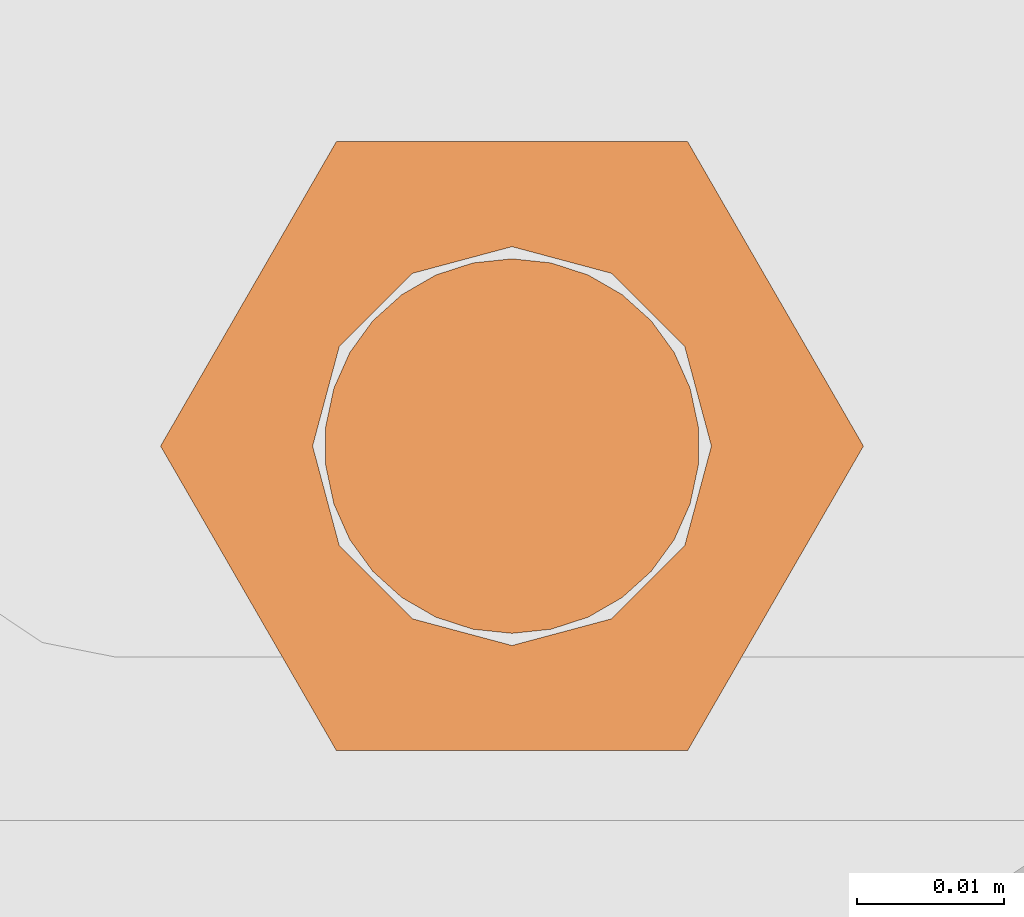
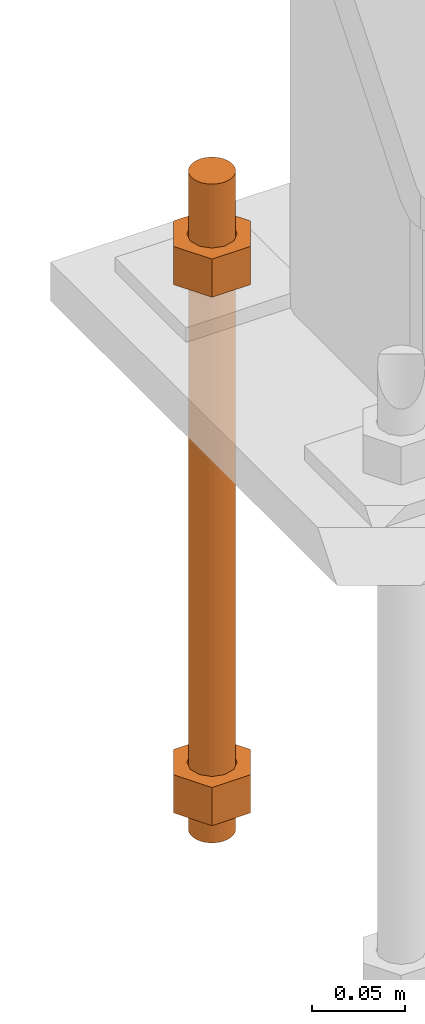
# One storey, part 28 of 89: 1 proxy.
"""IFC4 building model written with IfcOpenShell, lengths in feet."""

from ifc_helpers import new_model, entity, si_unit, converted_unit, derived_unit, direction, frame, origin, place, context, subcontext, project, spatial, faceted_brep, source, transform, mapped, material, constituent, constituent_set, type_object, type_shapes, element, save


model = new_model("IFC4")

# Units and contexts
model_context = context("Model", 3, precision=0.0001, world=origin(), true_north=direction((6.12303176911189e-17, 1.0)))
body_context = subcontext(model_context, "Body", "Model", "MODEL_VIEW")
ifc_project = project(units=[converted_unit("LENGTHUNIT", "FOOT", entity("IfcRatioMeasure", 0.3048), si_unit("LENGTHUNIT", "METRE"), dimensions=[1, 0, 0, 0, 0, 0, 0]), converted_unit("AREAUNIT", "SQUARE FOOT", entity("IfcRatioMeasure", 0.09290304), si_unit("AREAUNIT", "SQUARE_METRE"), dimensions=[2, 0, 0, 0, 0, 0, 0]), converted_unit("VOLUMEUNIT", "CUBIC FOOT", entity("IfcRatioMeasure", 0.028316846592), si_unit("VOLUMEUNIT", "CUBIC_METRE"), dimensions=[3, 0, 0, 0, 0, 0, 0]), si_unit("PLANEANGLEUNIT", "RADIAN"), si_unit("MASSUNIT", "GRAM", prefix="KILO"), derived_unit("MASSDENSITYUNIT", [(si_unit("MASSUNIT", "GRAM", prefix="KILO"), 1), (si_unit("LENGTHUNIT", "METRE"), -3)]), derived_unit("MOMENTOFINERTIAUNIT", [(si_unit("LENGTHUNIT", "METRE"), 4)]), si_unit("TIMEUNIT", "SECOND"), si_unit("FREQUENCYUNIT", "HERTZ"), si_unit("THERMODYNAMICTEMPERATUREUNIT", "DEGREE_CELSIUS"), derived_unit("THERMALTRANSMITTANCEUNIT", [(si_unit("MASSUNIT", "GRAM", prefix="KILO"), 1), (si_unit("THERMODYNAMICTEMPERATUREUNIT", "KELVIN"), -1), (si_unit("TIMEUNIT", "SECOND"), -3)]), derived_unit("VOLUMETRICFLOWRATEUNIT", [(si_unit("LENGTHUNIT", "METRE"), 3), (si_unit("TIMEUNIT", "SECOND"), -1)]), si_unit("ELECTRICCURRENTUNIT", "AMPERE"), si_unit("ELECTRICVOLTAGEUNIT", "VOLT"), si_unit("POWERUNIT", "WATT"), si_unit("FORCEUNIT", "NEWTON"), si_unit("ILLUMINANCEUNIT", "LUX"), si_unit("LUMINOUSFLUXUNIT", "LUMEN"), si_unit("LUMINOUSINTENSITYUNIT", "CANDELA"), derived_unit("USERDEFINED", [(si_unit("MASSUNIT", "GRAM", prefix="KILO"), -1), (si_unit("LENGTHUNIT", "METRE"), -2), (si_unit("TIMEUNIT", "SECOND"), 3), (si_unit("LUMINOUSFLUXUNIT", "LUMEN"), 1)]), derived_unit("LINEARVELOCITYUNIT", [(si_unit("LENGTHUNIT", "METRE"), 1), (si_unit("TIMEUNIT", "SECOND"), -1)]), si_unit("PRESSUREUNIT", "PASCAL"), derived_unit("USERDEFINED", [(si_unit("LENGTHUNIT", "METRE"), -2), (si_unit("MASSUNIT", "GRAM", prefix="KILO"), 1), (si_unit("TIMEUNIT", "SECOND"), -2)]), derived_unit("LINEARFORCEUNIT", [(si_unit("MASSUNIT", "GRAM", prefix="KILO"), 1), (si_unit("LENGTHUNIT", "METRE"), 1), (si_unit("TIMEUNIT", "SECOND"), -2), (si_unit("LENGTHUNIT", "METRE"), -1)]), derived_unit("PLANARFORCEUNIT", [(si_unit("MASSUNIT", "GRAM", prefix="KILO"), 1), (si_unit("LENGTHUNIT", "METRE"), 1), (si_unit("TIMEUNIT", "SECOND"), -2), (si_unit("LENGTHUNIT", "METRE"), -2)])], contexts=[model_context])

# Site, building, storey
site_placement = place(None, origin())
site = spatial("IfcSite", under=ifc_project, at=site_placement, CompositionType="ELEMENT")
building_placement = place(site_placement, frame((-472.238160486, -49.138065117, 0.0)))
building = spatial("IfcBuilding", under=site, at=building_placement, CompositionType="ELEMENT")
storey_placement = place(building_placement, origin())
storey = spatial("IfcBuildingStorey", under=building, at=storey_placement, Name="Level 1", CompositionType="ELEMENT", Elevation=0.0)

# Proxy
ifc_material_1 = material(Name="Color 7721", Category="Materials")
ifc_constituent_1 = constituent(ifc_material_1, Name="Color 7721", Category="Materials")
ifc_material_2 = material(Name="Color 7720", Category="Materials")
ifc_constituent_2 = constituent(ifc_material_2, Name="Color 7720", Category="Materials")
ifc_constituent_set = constituent_set(constituents=[ifc_constituent_1, ifc_constituent_2])
building_element_proxy_type = type_object("IfcBuildingElementProxyType", Name="rb2", PredefinedType="NOTDEFINED", material=ifc_material_1)
shared_shape = source(origin(), body_context, "Body", "Brep", [
    faceted_brep([(0.122545547339286, 0.0677083333333712, 0.0626666666666664), (0.156365697905557, 0.0677083333333712, 0.0626666666666664), (0.11727427342916, 0.135416666666742, 0.0626666666666664), (0.0390914244764247, 0.135416666666742, 0.0626666666666664), (0.0, 0.0677083333333712, 0.0626666666666664), (0.0338201505662994, 0.0677083333333712, 0.0626666666666664), (0.0397636251696838, 0.089889682526632, 0.0626666666666664), (0.0560014997595601, 0.106127557116452, 0.0626666666666664), (0.0781828489527925, 0.112071031719893, 0.0626666666666664), (0.100364198146025, 0.106127557116452, 0.0626666666666664), (0.116602072735901, 0.089889682526632, 0.0626666666666664), (0.11727427342916, 0.0, 0.0626666666666664), (0.0390914244764247, 0.0, 0.0626666666666664), (0.0397636251696838, 0.0455269841401105, 0.0626666666666664), (0.0560014997595601, 0.029289109550291, 0.0626666666666664), (0.0781828489527925, 0.0233456349468497, 0.0626666666666664), (0.100364198146025, 0.029289109550291, 0.0626666666666664), (0.116602072735901, 0.0455269841401105, 0.0626666666666664), (0.0, 0.0677083333333712, 0.144697916666667), (0.0390914244763962, 0.135416666666742, 0.144697916666667), (0.11727427342916, 0.135416666666742, 0.144697916666667), (0.156365697905528, 0.0677083333333712, 0.144697916666667), (0.117274273429189, 0.0, 0.144697916666667), (0.0390914244764247, 0.0, 0.144697916666667), (0.122545547339286, 0.0677083333333712, 0.144697916666666), (0.0338201505662994, 0.0677083333333712, 0.144697916666666), (0.0397636251696838, 0.0455269841401105, 0.144697916666666), (0.0560014997595601, 0.029289109550291, 0.144697916666666), (0.0781828489527925, 0.0233456349468497, 0.144697916666666), (0.100364198146025, 0.029289109550291, 0.144697916666666), (0.116602072735901, 0.0455269841401105, 0.144697916666666), (0.0397636251696838, 0.089889682526632, 0.144697916666666), (0.0560014997595601, 0.106127557116452, 0.144697916666666), (0.0781828489527925, 0.112071031719893, 0.144697916666666), (0.100364198146025, 0.106127557116452, 0.144697916666666), (0.116602072735901, 0.089889682526632, 0.144697916666666)], [[[0, 1, 2, 3, 4, 5, 6, 7, 8, 9, 10]], [[1, 11, 12, 4, 5, 13, 14, 15, 16, 17, 0]], [[4, 18, 19, 3]], [[3, 19, 20, 2]], [[2, 20, 21, 1]], [[1, 21, 22, 11]], [[11, 22, 23, 12]], [[12, 23, 18, 4]], [[24, 21, 22, 23, 18, 25, 26, 27, 28, 29, 30]], [[21, 20, 19, 18, 25, 31, 32, 33, 34, 35, 24]], [[25, 5, 6, 31]], [[31, 6, 7, 32]], [[32, 7, 8, 33]], [[33, 8, 9, 34]], [[34, 9, 10, 35]], [[35, 10, 0, 24]], [[24, 0, 17, 30]], [[30, 17, 16, 29]], [[29, 16, 15, 28]], [[28, 15, 14, 27]], [[27, 14, 13, 26]], [[26, 13, 5, 25]]]),
    faceted_brep([(0.0338201505662994, 0.0677083333333712, 1.28108333333333), (0.0, 0.0677083333333712, 1.28108333333333), (0.0390914244764247, 0.135416666666742, 1.28108333333333), (0.11727427342916, 0.135416666666742, 1.28108333333333), (0.156365697905557, 0.0677083333333712, 1.28108333333333), (0.122545547339286, 0.0677083333333712, 1.28108333333333), (0.116602072735901, 0.089889682526632, 1.28108333333333), (0.100364198146025, 0.106127557116452, 1.28108333333333), (0.0781828489527925, 0.112071031719893, 1.28108333333333), (0.0560014997595601, 0.106127557116452, 1.28108333333333), (0.0397636251696838, 0.089889682526632, 1.28108333333333), (0.0390914244764247, 0.0, 1.28108333333333), (0.11727427342916, 0.0, 1.28108333333333), (0.116602072735901, 0.0455269841401105, 1.28108333333333), (0.100364198146025, 0.029289109550291, 1.28108333333333), (0.0781828489527925, 0.0233456349468497, 1.28108333333333), (0.0560014997595601, 0.029289109550291, 1.28108333333333), (0.0397636251696838, 0.0455269841401105, 1.28108333333333), (0.156365697905585, 0.0677083333333712, 1.19905208333333), (0.117274273429189, 0.135416666666742, 1.19905208333333), (0.0390914244764247, 0.135416666666742, 1.19905208333333), (0.0, 0.0677083333333712, 1.19905208333333), (0.0390914244763962, 0.0, 1.19905208333333), (0.11727427342916, 0.0, 1.19905208333333), (0.0338201505662994, 0.0677083333333712, 1.19905208333333), (0.122545547339286, 0.0677083333333712, 1.19905208333333), (0.116602072735901, 0.0455269841401105, 1.19905208333333), (0.100364198146025, 0.029289109550291, 1.19905208333333), (0.0781828489527925, 0.0233456349468497, 1.19905208333333), (0.0560014997595601, 0.029289109550291, 1.19905208333333), (0.0397636251696838, 0.0455269841401105, 1.19905208333333), (0.116602072735901, 0.089889682526632, 1.19905208333333), (0.100364198146025, 0.106127557116452, 1.19905208333333), (0.0781828489527925, 0.112071031719893, 1.19905208333333), (0.0560014997595601, 0.106127557116452, 1.19905208333333), (0.0397636251696838, 0.089889682526632, 1.19905208333333)], [[[0, 1, 2, 3, 4, 5, 6, 7, 8, 9, 10]], [[1, 11, 12, 4, 5, 13, 14, 15, 16, 17, 0]], [[4, 18, 19, 3]], [[3, 19, 20, 2]], [[2, 20, 21, 1]], [[1, 21, 22, 11]], [[11, 22, 23, 12]], [[12, 23, 18, 4]], [[24, 21, 22, 23, 18, 25, 26, 27, 28, 29, 30]], [[21, 20, 19, 18, 25, 31, 32, 33, 34, 35, 24]], [[25, 5, 6, 31]], [[31, 6, 7, 32]], [[32, 7, 8, 33]], [[33, 8, 9, 34]], [[34, 9, 10, 35]], [[35, 10, 0, 24]], [[24, 0, 17, 30]], [[30, 17, 16, 29]], [[29, 16, 15, 28]], [[28, 15, 14, 27]], [[27, 14, 13, 26]], [[26, 13, 5, 25]]]),
    faceted_brep([(0.0781828489527925, 0.0260416666667425, 0.0), (0.0695198618353743, 0.0269521833027966, 0.0), (0.0612354888246216, 0.029643939264929, 0.0), (0.0536917967739328, 0.0339992919010683, 0.0), (0.0472184812245757, 0.0398278914017283, 0.0), (0.0420984571284464, 0.046875, 0.0), (0.0385554941071575, 0.0548326252344395, 0.0), (0.0367444366457903, 0.0633529806972319, 0.0), (0.0367444366457903, 0.0720636859695105, 0.0), (0.0385554941071575, 0.0805840414323029, 0.0), (0.0420984571284464, 0.0885416666667425, 0.0), (0.0472184812245757, 0.0955887752650142, 0.0), (0.0536917967739328, 0.101417374765674, 0.0), (0.0612354888246216, 0.105772727401813, 0.0), (0.0695198618353743, 0.108464483363946, 0.0), (0.0781828489527925, 0.109375, 0.0), (0.0868458360702107, 0.108464483363946, 0.0), (0.0951302090809634, 0.105772727401813, 0.0), (0.102673901131652, 0.101417374765674, 0.0), (0.109147216681009, 0.0955887752650142, 0.0), (0.114267240777139, 0.0885416666667425, 0.0), (0.117810203798427, 0.0805840414323029, 0.0), (0.119621261259795, 0.0720636859695105, 0.0), (0.119621261259795, 0.0633529806972319, 0.0), (0.117810203798427, 0.0548326252344395, 0.0), (0.114267240777139, 0.046875, 0.0), (0.109147216681009, 0.0398278914017283, 0.0), (0.102673901131652, 0.0339992919010683, 0.0), (0.0951302090809634, 0.029643939264929, 0.0), (0.0868458360702107, 0.0269521833027966, 0.0), (0.0868458360702107, 0.0269521833027966, 1.41666666666667), (0.0951302090809634, 0.029643939264929, 1.41666666666667), (0.102673901131652, 0.0339992919010683, 1.41666666666667), (0.109147216681009, 0.0398278914017283, 1.41666666666667), (0.114267240777139, 0.046875, 1.41666666666667), (0.117810203798427, 0.0548326252344395, 1.41666666666667), (0.119621261259795, 0.0633529806972319, 1.41666666666667), (0.119621261259795, 0.0720636859695105, 1.41666666666667), (0.117810203798427, 0.0805840414323029, 1.41666666666667), (0.114267240777139, 0.0885416666667425, 1.41666666666667), (0.109147216681009, 0.0955887752650142, 1.41666666666667), (0.102673901131652, 0.101417374765674, 1.41666666666667), (0.0951302090809634, 0.105772727401813, 1.41666666666667), (0.0868458360702107, 0.108464483363946, 1.41666666666667), (0.0781828489527925, 0.109375, 1.41666666666667), (0.0695198618353743, 0.108464483363946, 1.41666666666667), (0.0612354888246216, 0.105772727401813, 1.41666666666667), (0.0536917967739328, 0.101417374765674, 1.41666666666667), (0.0472184812245757, 0.0955887752650142, 1.41666666666667), (0.0420984571284464, 0.0885416666667425, 1.41666666666667), (0.0385554941071575, 0.0805840414323029, 1.41666666666667), (0.0367444366457903, 0.0720636859695105, 1.41666666666667), (0.0367444366457903, 0.0633529806972319, 1.41666666666667), (0.0385554941071575, 0.0548326252344395, 1.41666666666667), (0.0420984571284464, 0.046875, 1.41666666666667), (0.0472184812245757, 0.0398278914017283, 1.41666666666667), (0.0536917967739328, 0.0339992919010683, 1.41666666666667), (0.0612354888246216, 0.029643939264929, 1.41666666666667), (0.0695198618353743, 0.0269521833027966, 1.41666666666667), (0.0781828489527925, 0.0260416666667425, 1.41666666666667), (0.0695198618353743, 0.0269521833027966, 0.25), (0.0781828489527925, 0.0260416666667425, 0.25), (0.0612354888246216, 0.029643939264929, 0.25), (0.0536917967739328, 0.0339992919010683, 0.25), (0.0472184812246041, 0.0398278914017283, 0.25), (0.0420984571284464, 0.046875, 0.25), (0.0385554941071575, 0.0548326252344395, 0.25), (0.0367444366458187, 0.0633529806972319, 0.25), (0.0367444366457903, 0.0720636859695105, 0.25), (0.0385554941071575, 0.0805840414323029, 0.25), (0.0420984571284464, 0.0885416666667425, 0.25), (0.0472184812245757, 0.0955887752650142, 0.25), (0.0536917967739043, 0.101417374765674, 0.25), (0.0612354888246216, 0.105772727401813, 0.25), (0.0695198618353743, 0.108464483363946, 0.25), (0.0781828489527925, 0.109375, 0.25), (0.0868458360702107, 0.108464483363946, 0.25), (0.0951302090809634, 0.105772727401813, 0.25), (0.102673901131652, 0.101417374765674, 0.25), (0.109147216680981, 0.0955887752650142, 0.25), (0.114267240777139, 0.0885416666667425, 0.25), (0.117810203798427, 0.0805840414323029, 0.25), (0.119621261259766, 0.0720636859695105, 0.25), (0.119621261259795, 0.0633529806972319, 0.25), (0.117810203798427, 0.0548326252344395, 0.25), (0.114267240777139, 0.046875, 0.25), (0.109147216681009, 0.0398278914017283, 0.25), (0.102673901131681, 0.0339992919010683, 0.25), (0.0951302090809634, 0.029643939264929, 0.25), (0.0868458360702107, 0.0269521833027966, 0.25), (0.0695198618353743, 0.0269521833027966, 0.916666666666667), (0.0781828489527925, 0.0260416666667425, 0.916666666666667), (0.0612354888246216, 0.029643939264929, 0.916666666666667), (0.0536917967739328, 0.0339992919010683, 0.916666666666667), (0.0472184812246041, 0.0398278914017283, 0.916666666666667), (0.0420984571284464, 0.046875, 0.916666666666667), (0.0385554941071575, 0.0548326252344395, 0.916666666666667), (0.0367444366458187, 0.0633529806972319, 0.916666666666667), (0.0367444366457903, 0.0720636859695105, 0.916666666666667), (0.0385554941071575, 0.0805840414323029, 0.916666666666667), (0.0420984571284464, 0.0885416666667425, 0.916666666666667), (0.0472184812245757, 0.0955887752650142, 0.916666666666667), (0.0536917967739043, 0.101417374765674, 0.916666666666667), (0.0612354888246216, 0.105772727401813, 0.916666666666667), (0.0695198618353743, 0.108464483363946, 0.916666666666667), (0.0781828489527925, 0.109375, 0.916666666666667), (0.0868458360702107, 0.108464483363946, 0.916666666666667), (0.0951302090809634, 0.105772727401813, 0.916666666666667), (0.102673901131652, 0.101417374765674, 0.916666666666667), (0.109147216680981, 0.0955887752650142, 0.916666666666667), (0.114267240777139, 0.0885416666667425, 0.916666666666667), (0.117810203798427, 0.0805840414323029, 0.916666666666667), (0.119621261259766, 0.0720636859695105, 0.916666666666667), (0.119621261259795, 0.0633529806972319, 0.916666666666667), (0.117810203798427, 0.0548326252344395, 0.916666666666667), (0.114267240777139, 0.046875, 0.916666666666667), (0.109147216681009, 0.0398278914017283, 0.916666666666667), (0.102673901131681, 0.0339992919010683, 0.916666666666667), (0.0951302090809634, 0.029643939264929, 0.916666666666667), (0.0868458360702107, 0.0269521833027966, 0.916666666666667)], [[[0, 1, 2, 3, 4, 5, 6, 7, 8, 9, 10, 11, 12, 13, 14, 15, 16, 17, 18, 19, 20, 21, 22, 23, 24, 25, 26, 27, 28, 29]], [[30, 31, 32, 33, 34, 35, 36, 37, 38, 39, 40, 41, 42, 43, 44, 45, 46, 47, 48, 49, 50, 51, 52, 53, 54, 55, 56, 57, 58, 59]], [[60, 1, 0, 61]], [[62, 2, 1, 60]], [[63, 3, 2, 62]], [[64, 4, 3, 63]], [[65, 5, 4, 64]], [[66, 6, 5, 65]], [[67, 7, 6, 66]], [[68, 8, 7, 67]], [[69, 9, 8, 68]], [[70, 10, 9, 69]], [[71, 11, 10, 70]], [[72, 12, 11, 71]], [[73, 13, 12, 72]], [[74, 14, 13, 73]], [[75, 15, 14, 74]], [[76, 16, 15, 75]], [[77, 17, 16, 76]], [[78, 18, 17, 77]], [[79, 19, 18, 78]], [[80, 20, 19, 79]], [[81, 21, 20, 80]], [[82, 22, 21, 81]], [[83, 23, 22, 82]], [[84, 24, 23, 83]], [[85, 25, 24, 84]], [[86, 26, 25, 85]], [[87, 27, 26, 86]], [[88, 28, 27, 87]], [[89, 29, 28, 88]], [[61, 0, 29, 89]], [[90, 60, 61, 91]], [[92, 62, 60, 90]], [[93, 63, 62, 92]], [[94, 64, 63, 93]], [[95, 65, 64, 94]], [[96, 66, 65, 95]], [[97, 67, 66, 96]], [[98, 68, 67, 97]], [[99, 69, 68, 98]], [[100, 70, 69, 99]], [[101, 71, 70, 100]], [[102, 72, 71, 101]], [[103, 73, 72, 102]], [[104, 74, 73, 103]], [[105, 75, 74, 104]], [[106, 76, 75, 105]], [[107, 77, 76, 106]], [[108, 78, 77, 107]], [[109, 79, 78, 108]], [[110, 80, 79, 109]], [[111, 81, 80, 110]], [[112, 82, 81, 111]], [[113, 83, 82, 112]], [[114, 84, 83, 113]], [[115, 85, 84, 114]], [[116, 86, 85, 115]], [[117, 87, 86, 116]], [[118, 88, 87, 117]], [[119, 89, 88, 118]], [[91, 61, 89, 119]], [[58, 90, 91, 59]], [[57, 92, 90, 58]], [[56, 93, 92, 57]], [[55, 94, 93, 56]], [[54, 95, 94, 55]], [[53, 96, 95, 54]], [[52, 97, 96, 53]], [[51, 98, 97, 52]], [[50, 99, 98, 51]], [[49, 100, 99, 50]], [[48, 101, 100, 49]], [[47, 102, 101, 48]], [[46, 103, 102, 47]], [[45, 104, 103, 46]], [[44, 105, 104, 45]], [[43, 106, 105, 44]], [[42, 107, 106, 43]], [[41, 108, 107, 42]], [[40, 109, 108, 41]], [[39, 110, 109, 40]], [[38, 111, 110, 39]], [[37, 112, 111, 38]], [[36, 113, 112, 37]], [[35, 114, 113, 36]], [[34, 115, 114, 35]], [[33, 116, 115, 34]], [[32, 117, 116, 33]], [[31, 118, 117, 32]], [[30, 119, 118, 31]], [[59, 91, 119, 30]]]),
])
type_shapes(building_element_proxy_type, [shared_shape])
proxy_placement = place(building_placement, frame((199.588483817714, 1000.265625, -1.45833333333333)))
element("IfcBuildingElementProxy", 1, at=proxy_placement, inside=storey, type_object=building_element_proxy_type, material=ifc_constituent_set, Name="rb2 363:rb2 363", ObjectType="rb2 363:rb2 363", PredefinedType="NOTDEFINED", context=body_context, shape_type="MappedRepresentation", body=[
    mapped(shared_shape, transform((0.0, 0.0, 0.0), scale=1.0)),
])

save(model, "model.ifc")
